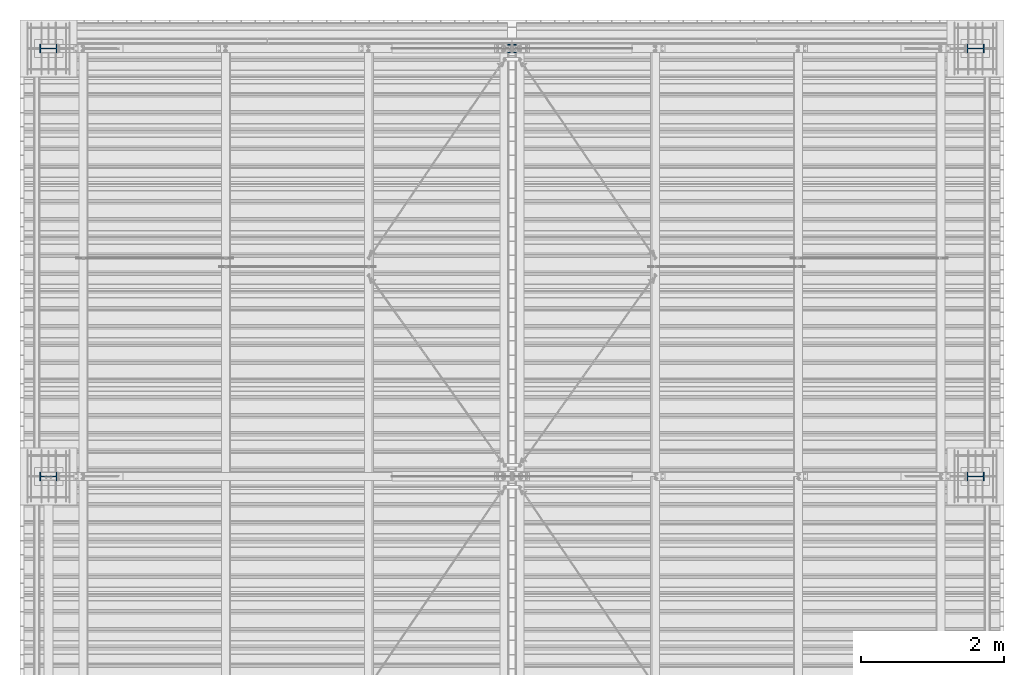
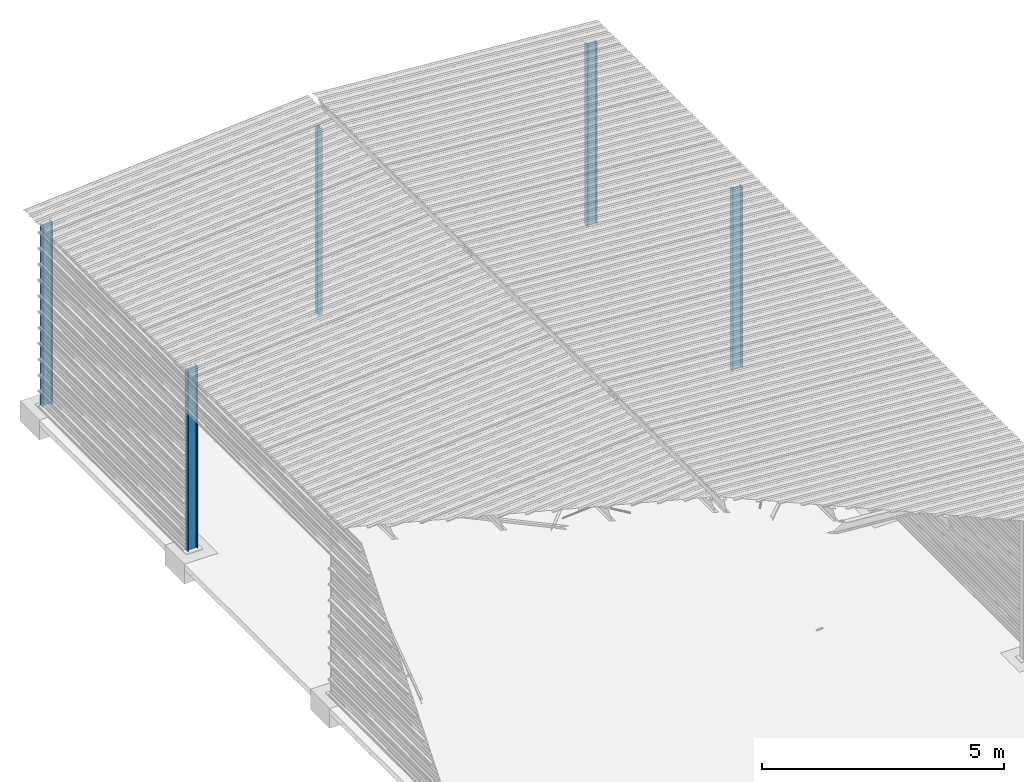
# One storey, part 3 of 70: 5 columns, 5 elements without a shape of their own.
"""IFC2X3 building model written with IfcOpenShell, lengths in millimetres."""

from ifc_helpers import new_model, si_unit, frame, origin_with_axes, origin_2d_with_axis, place, context, subcontext, project, spatial, i_section, extrude, clip, halfspace, material, type_object, element, aggregate, save


model = new_model("IFC2X3")

# Units and contexts
model_context = context("Model", 3, precision=1e-05, world=origin_with_axes())
body_context = subcontext(model_context, "Body", "Model", "MODEL_VIEW")
ifc_project = project(units=[si_unit("LENGTHUNIT", "METRE", prefix="MILLI"), si_unit("AREAUNIT", "SQUARE_METRE"), si_unit("VOLUMEUNIT", "CUBIC_METRE"), si_unit("MASSUNIT", "GRAM", prefix="KILO"), si_unit("TIMEUNIT", "SECOND"), si_unit("PLANEANGLEUNIT", "RADIAN"), si_unit("SOLIDANGLEUNIT", "STERADIAN"), si_unit("THERMODYNAMICTEMPERATUREUNIT", "DEGREE_CELSIUS"), si_unit("LUMINOUSINTENSITYUNIT", "LUMEN")], contexts=[model_context])

# Site, building, storey
site_placement = place(None, origin_with_axes())
site = spatial("IfcSite", under=ifc_project, at=site_placement, CompositionType="ELEMENT")
building_placement = place(site_placement, origin_with_axes())
building = spatial("IfcBuilding", under=site, at=building_placement, Name="Undefined", CompositionType="ELEMENT")
storey_placement = place(building_placement, origin_with_axes())
storey = spatial("IfcBuildingStorey", under=building, at=storey_placement, Name="Undefined", CompositionType="ELEMENT", Elevation=0.0)

# Assembly, column
assembly_1_placement = place(storey_placement, origin_with_axes())
assembly_1 = element("IfcElementAssembly", 1, at=assembly_1_placement, inside=storey, Name="Steel Assembly", AssemblyPlace="NOTDEFINED", PredefinedType="RIGID_FRAME")
ifc_material = material(Name="STEEL/S235JR")
column_type_1 = type_object("IfcColumnType", Name="HEA120", PredefinedType="NOTDEFINED")
column_1_placement = place(assembly_1_placement, frame((6500.0, 24000.0, 5.0), z_axis=(0.0, 0.0, 1.0), x_axis=(0.0, 1.0, 0.0)))
column_1 = element("IfcColumn", 2, at=column_1_placement, type_object=column_type_1, material=ifc_material, Name="POTEAU", ObjectType="HEA120", context=body_context, shape_type="SweptSolid", body=[
    extrude(i_section(OverallWidth=120.0, OverallDepth=114.0, WebThickness=5.0, FlangeThickness=8.0, FilletRadius=12.0, at=origin_2d_with_axis()), frame((0.0, 0.0, 4724.67503646996), z_axis=(0.0, 0.0, -1.0), x_axis=(0.0, 1.0, 0.0)), (0.0, 0.0, 1.0), 4724.68),
])
aggregate(assembly_1, [column_1])

assembly_2_placement = place(storey_placement, origin_with_axes())
assembly_2 = element("IfcElementAssembly", 3, at=assembly_2_placement, inside=storey, Name="Steel Assembly", AssemblyPlace="NOTDEFINED", PredefinedType="RIGID_FRAME")
column_type_2 = type_object("IfcColumnType", Name="IPE240", PredefinedType="NOTDEFINED")
column_2_placement = place(assembly_2_placement, frame((13000.0, 24000.0, 0.0), z_axis=(0.0, 0.0, 1.0), x_axis=(1.0, 0.0, 0.0)))
column_2 = element("IfcColumn", 4, at=column_2_placement, type_object=column_type_2, material=ifc_material, Name="POTEAU", ObjectType="IPE240", context=body_context, shape_type="Clipping", body=[
    clip(extrude(i_section(OverallWidth=120.0, OverallDepth=240.0, WebThickness=6.199999809, FlangeThickness=9.800000191, FilletRadius=15.0, at=origin_2d_with_axis()), frame((0.0, 0.0, 4599.29353476665), z_axis=(0.0, 0.0, -1.0), x_axis=(0.0, 1.0, 0.0)), (0.0, 0.0, 1.0), 4599.29), halfspace(frame((-170.766964989612, 0.0, 4603.10637823504), z_axis=(0.0766964990376782, 0.0, 0.997054485489817), x_axis=(0.997054485489817, 0.0, -0.0766964990376783)), False)),
])
aggregate(assembly_2, [column_2])

assembly_3_placement = place(storey_placement, origin_with_axes())
assembly_3 = element("IfcElementAssembly", 5, at=assembly_3_placement, inside=storey, Name="Steel Assembly", AssemblyPlace="NOTDEFINED", PredefinedType="RIGID_FRAME")
column_3_placement = place(assembly_3_placement, frame((0.0, 24000.0, 0.0), z_axis=(0.0, 0.0, 1.0), x_axis=(1.0, 0.0, 0.0)))
column_3 = element("IfcColumn", 6, at=column_3_placement, type_object=column_type_2, material=ifc_material, Name="POTEAU", ObjectType="IPE240", context=body_context, shape_type="Clipping", body=[
    clip(extrude(i_section(OverallWidth=120.0, OverallDepth=240.0, WebThickness=6.199999809, FlangeThickness=9.800000191, FilletRadius=15.0, at=origin_2d_with_axis()), frame((0.0, 0.0, 4599.29353476665), z_axis=(0.0, 0.0, -1.0), x_axis=(0.0, 1.0, 0.0)), (0.0, 0.0, 1.0), 4599.29), halfspace(frame((170.766964989612, 0.0, 4603.10637823504), z_axis=(-0.0766964990376602, 0.0, 0.997054485489818), x_axis=(0.0, -1.0, 0.0)), False)),
])
aggregate(assembly_3, [column_3])

assembly_4_placement = place(storey_placement, origin_with_axes())
assembly_4 = element("IfcElementAssembly", 7, at=assembly_4_placement, inside=storey, Name="Steel Assembly", AssemblyPlace="NOTDEFINED", PredefinedType="RIGID_FRAME")
column_4_placement = place(assembly_4_placement, frame((13000.0, 18000.0, 0.0), z_axis=(0.0, 0.0, 1.0), x_axis=(1.0, 0.0, 0.0)))
column_4 = element("IfcColumn", 8, at=column_4_placement, type_object=column_type_2, material=ifc_material, Name="POTEAU", ObjectType="IPE240", context=body_context, shape_type="Clipping", body=[
    clip(extrude(i_section(OverallWidth=120.0, OverallDepth=240.0, WebThickness=6.199999809, FlangeThickness=9.800000191, FilletRadius=15.0, at=origin_2d_with_axis()), frame((0.0, 0.0, 4599.29353476665), z_axis=(0.0, 0.0, -1.0), x_axis=(0.0, 1.0, 0.0)), (0.0, 0.0, 1.0), 4599.29), halfspace(frame((-170.766964989612, 0.0, 4603.10637823504), z_axis=(0.0766964990376782, 0.0, 0.997054485489817), x_axis=(0.997054485489817, 0.0, -0.0766964990376783)), False)),
])
aggregate(assembly_4, [column_4])

assembly_5_placement = place(storey_placement, origin_with_axes())
assembly_5 = element("IfcElementAssembly", 9, at=assembly_5_placement, inside=storey, Name="Steel Assembly", AssemblyPlace="NOTDEFINED", PredefinedType="RIGID_FRAME")
column_5_placement = place(assembly_5_placement, frame((0.0, 18000.0, 0.0), z_axis=(0.0, 0.0, 1.0), x_axis=(1.0, 0.0, 0.0)))
column_5 = element("IfcColumn", 10, at=column_5_placement, type_object=column_type_2, material=ifc_material, Name="POTEAU", ObjectType="IPE240", context=body_context, shape_type="Clipping", body=[
    clip(extrude(i_section(OverallWidth=120.0, OverallDepth=240.0, WebThickness=6.199999809, FlangeThickness=9.800000191, FilletRadius=15.0, at=origin_2d_with_axis()), frame((0.0, 0.0, 4599.29353476665), z_axis=(0.0, 0.0, -1.0), x_axis=(0.0, 1.0, 0.0)), (0.0, 0.0, 1.0), 4599.29), halfspace(frame((170.766964989612, 0.0, 4603.10637823504), z_axis=(-0.0766964990376602, 0.0, 0.997054485489818), x_axis=(0.0, -1.0, 0.0)), False)),
])
aggregate(assembly_5, [column_5])

save(model, "model.ifc")
